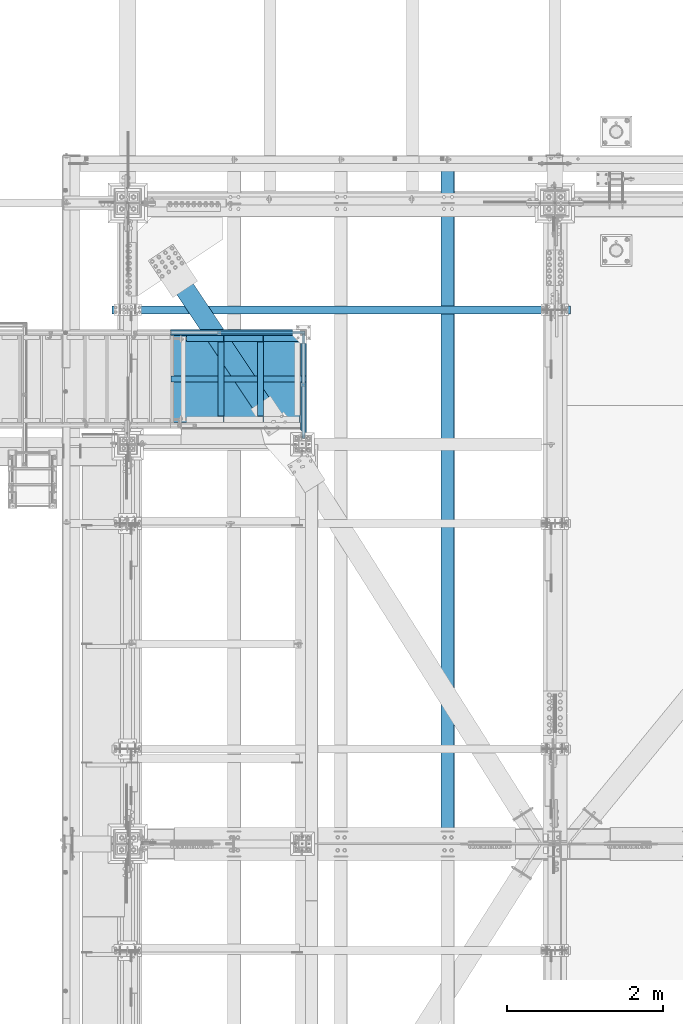
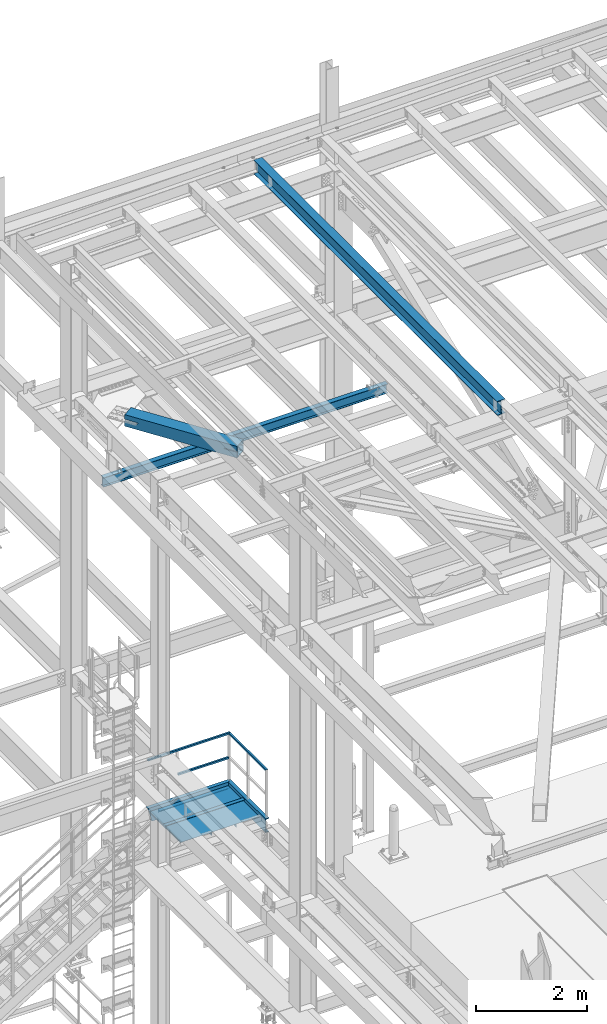
# One storey, part 1887 of 3843: 12 beams, 1 member, 7 elements without a shape of their own.
"""IFC2X3 building model written with IfcOpenShell, lengths in millimetres."""

from ifc_helpers import new_model, si_unit, frame, origin_with_axes, place, context, subcontext, project, spatial, faceted_brep, material, type_object, element, aggregate, save


model = new_model("IFC2X3")

# Units and contexts
model_context = context("Model", 3, precision=1e-05, world=origin_with_axes())
body_context = subcontext(model_context, "Body", "Model", "MODEL_VIEW")
ifc_project = project(units=[si_unit("LENGTHUNIT", "METRE", prefix="MILLI"), si_unit("AREAUNIT", "SQUARE_METRE"), si_unit("VOLUMEUNIT", "CUBIC_METRE"), si_unit("MASSUNIT", "GRAM", prefix="KILO"), si_unit("TIMEUNIT", "SECOND"), si_unit("PLANEANGLEUNIT", "RADIAN"), si_unit("SOLIDANGLEUNIT", "STERADIAN"), si_unit("THERMODYNAMICTEMPERATUREUNIT", "DEGREE_CELSIUS"), si_unit("LUMINOUSINTENSITYUNIT", "LUMEN")], contexts=[model_context])

# Site, building, storey
site_placement = place(None, origin_with_axes())
site = spatial("IfcSite", under=ifc_project, at=site_placement, CompositionType="ELEMENT")
building_placement = place(site_placement, origin_with_axes())
building = spatial("IfcBuilding", under=site, at=building_placement, Name="Undefined", CompositionType="ELEMENT")
storey_placement = place(building_placement, origin_with_axes())
storey = spatial("IfcBuildingStorey", under=building, at=storey_placement, Name="Undefined", CompositionType="ELEMENT", Elevation=0.0)

# Assembly, beam
assembly_1_placement = place(storey_placement, origin_with_axes())
assembly_1 = element("IfcElementAssembly", 1, at=assembly_1_placement, inside=storey, Name="RAIL", AssemblyPlace="NOTDEFINED", PredefinedType="RIGID_FRAME")
ifc_material_1 = material()
beam_type_1 = type_object("IfcBeamType", Name="HSS1-1/2X1-1/2X1/4", PredefinedType="NOTDEFINED")
beam_1_placement = place(assembly_1_placement, frame((38833.4250001418, 89211.15, 35204.399999695), z_axis=(0.0, 0.0, -1.0), x_axis=(0.0, 1.0, 0.0)))
beam_1 = element("IfcBeam", 2, at=beam_1_placement, type_object=beam_type_1, material=ifc_material_1, Name="RAIL", ObjectType="HSS1-1/2X1-1/2X1/4", context=body_context, shape_type="Brep", body=[
    faceted_brep([(-19.0499992359546, -19.0499992350015, -19.0499992350015), (-19.0499992359546, 19.0499992350015, -19.0499992350015), (1320.80000004543, 19.0499992350015, -19.0499992350015), (1320.80000004543, -19.0499992350015, -19.0499992350015), (19.0499992350015, -19.0499992350015, 19.0499992350015), (1320.80000004543, -19.0499999110762, 19.0499992350015), (19.0499992350015, 19.0499992350015, 19.0499992350015), (1320.80000004543, 19.0499992350015, 19.0499992350015), (12.6999993290483, 12.6999993299978, 12.6999993299978), (12.6999993290483, -12.6999993299978, 12.6999993299978), (-12.6999993309546, -12.6999993299978, -12.6999993299978), (-12.6999993309546, 12.6999993299978, -12.6999993299978), (1320.79999855565, 12.6999993299978, -12.6999993300014), (1320.80000004543, 12.6999993299978, 12.6999993299978), (1320.80000004543, -12.6999993299978, 12.6999993299978), (1320.79999855565, -12.6999993299978, -12.6999993300014)], [[[0, 1, 2, 3]], [[4, 0, 3, 5]], [[6, 4, 5, 7]], [[1, 6, 7, 2]], [[0, 4, 6, 1], [8, 9, 10, 11]], [[8, 11, 12, 13]], [[9, 8, 13, 14]], [[10, 9, 14, 15]], [[11, 10, 15, 12]], [[5, 3, 2, 7], [14, 13, 12, 15]]]),
])
aggregate(assembly_1, [beam_1])

# Assembly, beams
assembly_2_placement = place(storey_placement, origin_with_axes())
assembly_2 = element("IfcElementAssembly", 3, at=assembly_2_placement, inside=storey, Name="RAIL", AssemblyPlace="NOTDEFINED", PredefinedType="RIGID_FRAME")
beam_2_placement = place(assembly_2_placement, frame((37752.5642859121, 90551.0000000455, 34670.9999996949), z_axis=(0.0, 0.0, 1.0), x_axis=(1.0, 0.0, 0.0)))
beam_2 = element("IfcBeam", 4, at=beam_2_placement, type_object=beam_type_1, material=ifc_material_1, Name="RAIL", ObjectType="HSS1-1/2X1-1/2X1/4", context=body_context, shape_type="Brep", body=[
    faceted_brep([(1061.81071431866, -19.0500000000029, 19.0499992350015), (1061.81071435828, -19.0499992349942, -19.0499992350015), (1061.81071431866, 19.0499992349942, -19.0499992350015), (1061.81071431866, 19.0499992349942, 19.0499992350015), (1061.81071431866, -12.6999993299978, 12.6999993299978), (1061.81071431866, 12.6999993299978, 12.6999993299978), (1061.81071431866, 12.6999993299978, -12.6999993299978), (1061.81071431866, -12.6999993299978, -12.6999993299978), (19.0499992350015, 19.0499992350015, -19.0499992350015), (19.0499992350015, 19.0499992350015, 19.0499992350015), (19.0499992350015, -19.0499992350015, 19.0499992350015), (19.0499992350015, -19.0499992350015, -19.0499992350015), (19.0499992350015, 12.6999993299978, 12.6999993299978), (19.0499992350015, -12.6999993299978, 12.6999993299978), (19.0499992350015, -12.6999993299978, -12.6999993299978), (19.0499992350015, 12.6999993299978, -12.6999993299978)], [[[0, 1, 2, 3], [4, 5, 6, 7]], [[8, 9, 3, 2]], [[9, 10, 0, 3]], [[10, 11, 1, 0]], [[11, 8, 2, 1]], [[11, 10, 9, 8], [12, 13, 14, 15]], [[14, 13, 4, 7]], [[15, 14, 7, 6]], [[12, 15, 6, 5]], [[13, 12, 5, 4]]]),
])
beam_3_placement = place(assembly_2_placement, frame((38852.4750002307, 90551.0000000455, 35204.3999996949), z_axis=(0.0, 0.0, -1.0), x_axis=(-1.0, 0.0, 0.0)))
beam_3 = element("IfcBeam", 5, at=beam_3_placement, type_object=beam_type_1, material=ifc_material_1, Name="RAIL", ObjectType="HSS1-1/2X1-1/2X1/4", context=body_context, shape_type="Brep", body=[
    faceted_brep([(6.34999999999854, 12.6999993299978, -12.6999993299978), (6.34999999999854, -12.6999993299978, -12.6999993299978), (1721.30928479847, -12.6999993299978, -12.6999993299978), (1721.30928479847, 12.6999993299978, -12.6999993299978), (31.7500007135677, -12.6999993300014, 12.6999993299978), (1714.04071512254, -12.6999993299978, 12.6999993299978), (31.7500007135677, 12.6999993300014, 12.6999993299978), (1714.04071512254, 12.6999993299978, 12.6999993299978), (0.0, 19.0500000000029, -19.0499999999993), (38.0999984699883, 19.0499992350015, 19.0499992350015), (1712.22357263487, 19.0499992349942, 19.0499992350015), (1723.12642728614, 19.0499992349942, -19.0499992350015), (38.0999984699883, -19.0499992350015, 19.0499992350015), (1712.22357263487, -19.0499992349942, 19.0499992350015), (0.0, -19.0499992350015, -19.0499992350015), (1723.12642728614, -19.0499992349942, -19.0499992350015)], [[[0, 1, 2, 3]], [[1, 4, 5, 2]], [[4, 6, 7, 5]], [[6, 0, 3, 7]], [[8, 9, 10, 11]], [[9, 12, 13, 10]], [[12, 14, 15, 13]], [[14, 8, 11, 15]], [[13, 15, 11, 10], [5, 7, 3, 2]], [[14, 12, 9, 8], [6, 4, 1, 0]]]),
])
aggregate(assembly_2, [beam_2, beam_3])

assembly_3_placement = place(storey_placement, origin_with_axes())
assembly_3 = element("IfcElementAssembly", 6, at=assembly_3_placement, inside=storey, Name="STAIR", AssemblyPlace="NOTDEFINED", PredefinedType="RIGID_FRAME")
ifc_material_2 = material(Name="STEEL/A36")
beam_type_2 = type_object("IfcBeamType", Name="C12X20.7", PredefinedType="NOTDEFINED")
beam_4_placement = place(assembly_3_placement, frame((38833.4249999936, 89115.9000000001, 34010.6), z_axis=(0.0, 0.0, 1.0), x_axis=(0.0, 1.0, 0.0)))
beam_4 = element("IfcBeam", 7, at=beam_4_placement, type_object=beam_type_2, material=ifc_material_2, Name="STAIR", ObjectType="C12X20.7", context=body_context, shape_type="Brep", body=[
    faceted_brep([(1401.4901281567, 33.6098719394649, 146.050000096482), (1390.65000009617, 38.0999999999985, 150.540128157008), (1388.01974411152, 38.0999999999985, 152.400000000001), (1464.21974411151, -38.0999999999985, 152.400000000001), (1473.20000009616, -38.0999999999985, 146.047460000002), (1388.0197441115, 38.0999999999985, -152.400000000001), (1390.65000009617, 38.0999999999985, -150.540128156994), (1401.4901281567, 33.6098719394649, -146.050000096475), (1473.20000009616, -38.0999999999985, -146.047460000002), (1464.2197441115, -38.0999999999985, -152.400000000001), (63.4999999998981, -38.0999999999985, -146.047460000002), (63.4999999998981, -38.0999999999985, -152.400000000001), (63.4999999998981, 30.1624999999985, -134.674927499997), (1404.93750009616, 30.1624999999985, -134.674927499997), (63.4999999998981, 30.1624999999985, 134.674927499997), (1404.93750009616, 30.1624999999985, 134.674927499997), (63.4999999998981, -38.0999999999985, 146.047460000002), (63.4999999998981, -38.0999999999985, 152.400000000001), (63.4999999998981, 38.0999999999985, 152.400000000001), (63.4999999998981, 38.0999999999985, -152.400000000001)], [[[0, 1, 2, 3, 4]], [[5, 6, 7, 8, 9]], [[7, 6, 1, 0]], [[10, 11, 9, 8]], [[12, 10, 8, 13]], [[14, 12, 13, 15]], [[16, 14, 15, 4]], [[17, 16, 4, 3]], [[18, 17, 3, 2]], [[11, 10, 12, 14, 16, 17, 18, 19]], [[11, 19, 5, 9]], [[15, 13, 8, 7, 0, 4]], [[6, 5, 19, 18, 2, 1]]]),
])
beam_5_placement = place(assembly_3_placement, frame((38871.525, 90551.0000000963, 34010.5999999998), z_axis=(0.0, 0.0, 1.0), x_axis=(-1.0, 0.0, 0.0)))
beam_5 = element("IfcBeam", 8, at=beam_5_placement, type_object=beam_type_2, material=ifc_material_2, Name="STAIR", ObjectType="C12X20.7", context=body_context, shape_type="Brep", body=[
    faceted_brep([(76.2000000064072, 38.1000000000058, -152.400000000001), (76.2000000064072, 38.1000000000058, 152.400000000001), (1743.99357001703, 38.1000000000058, 152.400000000001), (1656.77072930426, 38.1000000000058, -152.400000000001), (0.0, -38.0999999999985, 152.400000000001), (1743.99357001703, -38.1000000000058, 152.400000000001), (0.0, -38.0999999999985, 146.047460000002), (1742.17570064518, -38.1000000000058, 146.047460000002), (68.2625000000044, 30.1624999999985, 134.674927499997), (1738.92128925821, 30.1625000000058, 134.674927499997), (68.2625000000044, 30.1624999999985, -134.674927499997), (1661.84301006309, 30.1625000000058, -134.674927499997), (0.0, -38.0999999999985, -146.047460000002), (1658.58859867612, -38.1000000000058, -146.047460000002), (0.0, -38.0999999999985, -152.400000000001), (1656.77072930426, -38.1000000000058, -152.400000000001)], [[[0, 1, 2, 3]], [[1, 4, 5, 2]], [[4, 6, 7, 5]], [[6, 8, 9, 7]], [[8, 10, 11, 9]], [[10, 12, 13, 11]], [[12, 14, 15, 13]], [[14, 0, 3, 15]], [[5, 7, 9, 11, 13, 15, 3, 2]], [[14, 12, 10, 8, 6, 4, 1, 0]]]),
])

# Assembly, beam
assembly_4_placement = place(storey_placement, origin_with_axes())
assembly_4 = element("IfcElementAssembly", 9, at=assembly_4_placement, inside=storey, Name="BEAM", AssemblyPlace="NOTDEFINED", PredefinedType="RIGID_FRAME")
ifc_material_3 = material(Name="STEEL/A992")
beam_type_3 = type_object("IfcBeamType", Name="W12X26", PredefinedType="NOTDEFINED")
beam_6_placement = place(assembly_4_placement, frame((40687.509262353, 83985.1349347832, 45662.9566294508), z_axis=(-0.0211520975410895, 0.000224553000021843, 0.999776244139439), x_axis=(0.0, 0.999999974776746, -0.000224602999950078)))
beam_6 = element("IfcBeam", 10, at=beam_6_placement, type_object=beam_type_3, material=ifc_material_3, Name="BEAM", ObjectType="W12X26", context=body_context, shape_type="Brep", body=[
    faceted_brep([(8748.71311540117, -3.17500000010477, -146.049999983072), (8748.71311540117, -82.5499999999593, -146.049999983014), (8748.71311540123, -82.549999999952, -155.574999982986), (8748.71311540125, 82.5499999997628, -155.574999983102), (8748.71311540117, 82.5499999997483, -146.04999998313), (8748.71311540117, 3.1749999998865, -146.049999983079), (8748.71311540167, 3.1749999998865, -142.874999540705), (8748.71311540162, -3.17500000011205, -142.874999540683), (8749.67984532419, 3.17499999987194, -138.014920022666), (8749.67984532416, -3.17500000011205, -138.014920022644), (8752.43285922469, 3.17499999986467, -133.894743554527), (8752.43285922465, -3.1750000001266, -133.894743554505), (8756.55303569289, 3.17499999985739, -131.141729654068), (8756.55303569286, -3.17500000013388, -131.141729654046), (8761.41311521103, 3.17499999985739, -130.174999731513), (8761.41311521101, -3.17500000013388, -130.174999731491), (8818.55700377848, -3.17500000013388, -130.174999732226), (8818.55703394623, 3.17499999985739, -130.174999732219), (12.6322846896801, 3.17499999975553, 146.049999999632), (12.6326617865998, 82.5499999996173, 146.049999999574), (8748.71311539768, 82.549999999268, 146.050000016097), (8748.71311539767, 3.17499999941356, 146.050000016156), (12.699601046821, -82.5500000001557, -155.574999999742), (12.6974692860676, -82.54999999961, -146.049999999537), (12.6977969192812, -3.17500000026484, -146.049999999916), (12.63225452193, -3.17500000023574, 146.049999999646), (12.6318774249958, -82.5500000000975, 146.049999999697), (12.629738559961, -82.550000000112, 155.574999999677), (12.630522921565, 82.5499999995955, 155.574999999553), (12.6978276350128, 3.17499999971187, -146.04999999993), (12.6982115817373, 82.5499999995736, -146.050000000097), (12.7003686724711, 82.5499999999884, -155.574999999677), (8748.71311539768, -3.17500000058499, 146.050000016156), (8748.71311539767, -82.5500000004467, 146.050000016221), (8748.71311539761, -82.5500000004613, 155.575000016193), (8748.71311539761, 82.5499999992462, 155.575000016077), (8748.71311539839, -3.17500000057771, 142.875000076056), (8748.71311539842, 3.17499999940628, 142.875000076041), (8749.67984532106, -3.17500000057771, 138.014920558082), (8749.67984532111, 3.17499999942083, 138.014920558067), (8752.4328592216, -3.17500000056316, 133.894744089979), (8752.43285922163, 3.17499999942083, 133.894744089965), (8756.55303568982, -3.17500000056316, 131.141730189527), (8756.55303568985, 3.17499999942083, 131.141730189505), (8761.41311520792, -3.17500000056316, 130.175000266914), (8761.41311520795, 3.17499999942811, 130.1750002669), (8818.49854146753, -3.17500000057044, 130.175000267431), (8818.4985716353, 3.17499999942811, 130.175000267445), (8818.5532037197, 3.17499999982101, -113.117865648703), (8818.50142185467, 3.17499999944266, 117.482128538446)], [[[0, 1, 2, 3, 4, 5, 6, 7]], [[7, 6, 8, 9]], [[9, 8, 10, 11]], [[11, 10, 12, 13]], [[13, 12, 14, 15]], [[16, 15, 14, 17]], [[18, 19, 20, 21]], [[22, 23, 24, 25, 26, 27, 28, 19, 18, 29, 30, 31]], [[26, 25, 32, 33]], [[27, 26, 33, 34]], [[28, 27, 34, 35]], [[19, 28, 35, 20]], [[34, 33, 32, 36, 37, 21, 20, 35]], [[38, 39, 37, 36]], [[40, 41, 39, 38]], [[42, 43, 41, 40]], [[44, 45, 43, 42]], [[46, 47, 45, 44]], [[48, 49, 47, 46, 16, 17]], [[12, 10, 8, 6, 5, 29, 18, 21, 37, 39, 41, 43, 45, 47, 49, 48, 17, 14]], [[30, 29, 5, 4]], [[31, 30, 4, 3]], [[22, 31, 3, 2]], [[23, 22, 2, 1]], [[24, 23, 1, 0]], [[46, 44, 42, 40, 38, 36, 32, 25, 24, 0, 7, 9, 11, 13, 15, 16]]]),
])
aggregate(assembly_4, [beam_6])

# Beam
beam_type_4 = type_object("IfcBeamType", Name="L3X3X1/4", PredefinedType="NOTDEFINED")
beam_7_placement = place(assembly_3_placement, frame((37772.974999991, 90506.5500001432, 34048.7000000116), z_axis=(-1.0, 0.0, 0.0), x_axis=(0.0, -1.0, 0.0)))
beam_7 = element("IfcBeam", 11, at=beam_7_placement, type_object=beam_type_4, material=ifc_material_2, Name="ANGLE", ObjectType="L3X3X1/4", context=body_context, shape_type="Brep", body=[
    faceted_brep([(1035.05000022112, 31.75, 38.0999999999985), (1035.05000022112, 31.75, -31.75), (1035.05000022112, 31.7499999999927, -38.0999999999985), (1028.70000022053, 38.0999999999985, -38.0999999999985), (1028.70000022053, 38.0999999999985, 38.0999999999985), (1092.20000022113, 31.75, -31.75), (1092.20000022113, 31.7499999999927, -38.0999999999985), (1104.90000022113, 19.0499999999884, -31.75), (1104.90000015372, 19.0499999999884, -38.0999999999985), (76.2000000006228, 38.0999999999985, 38.0999999999985), (76.2000000006228, 38.0999999999985, -38.0999999999985), (69.8500000000349, 31.7499999999927, -38.0999999999985), (69.8500000000349, 31.75, -31.75), (69.8500000000349, 31.75, 38.0999999999985), (12.7000000000262, 31.7499999999927, -38.0999999999985), (12.7000000000262, 31.75, -31.75), (0.0, 19.0499999999884, -38.0999999999985), (0.0, 19.0500000000029, -31.75), (0.0, -38.0999999999985, -38.0999999999985), (0.0, -38.0999999999985, -31.75), (1104.90000015372, -38.0999999999985, -38.0999999999985), (1104.90000015372, -38.0999999999985, -31.75)], [[[0, 1, 2, 3, 4]], [[5, 6, 2, 1]], [[7, 8, 6, 5]], [[9, 10, 11, 12, 13]], [[12, 11, 14, 15]], [[15, 14, 16, 17]], [[18, 19, 17, 16]], [[19, 18, 20, 21]], [[1, 12, 15, 17, 19, 21, 7, 5]], [[13, 12, 1, 0]], [[9, 13, 0, 4]], [[10, 9, 4, 3]], [[20, 18, 16, 14, 11, 10, 3, 2, 6, 8]], [[21, 20, 8, 7]]]),
])

beam_8_placement = place(assembly_3_placement, frame((38284.1499999923, 90506.5500001432, 34048.7000000114), z_axis=(-1.0, 0.0, 0.0), x_axis=(0.0, -1.0, 0.0)))
beam_8 = element("IfcBeam", 12, at=beam_8_placement, type_object=beam_type_4, material=ifc_material_2, Name="ANGLE", ObjectType="L3X3X1/4", context=body_context, shape_type="Brep", body=[
    faceted_brep([(1035.05000022112, 31.75, 38.0999999999985), (1035.05000022112, 31.75, -31.75), (1035.05000022112, 31.7499999999927, -38.0999999999985), (1028.70000022053, 38.0999999999985, -38.0999999999985), (1028.70000022053, 38.0999999999985, 38.0999999999985), (1092.20000022113, 31.75, -31.75), (1092.20000022113, 31.7499999999927, -38.0999999999985), (1104.90000022113, 19.0499999999884, -31.75), (1104.90000015372, 19.0499999999884, -38.0999999999985), (76.2000000006228, 38.0999999999985, 38.0999999999985), (76.2000000006228, 38.0999999999985, -38.0999999999985), (69.8500000000349, 31.7499999999927, -38.0999999999985), (69.8500000000349, 31.75, -31.75), (69.8500000000349, 31.75, 38.0999999999985), (12.7000000000262, 31.7499999999927, -38.0999999999985), (12.7000000000262, 31.75, -31.75), (0.0, 19.0499999999884, -38.0999999999985), (0.0, 19.0500000000029, -31.75), (0.0, -38.0999999999985, -38.0999999999985), (0.0, -38.0999999999985, -31.75), (1104.90000015372, -38.0999999999985, -38.0999999999985), (1104.90000015372, -38.0999999999985, -31.75)], [[[0, 1, 2, 3, 4]], [[5, 6, 2, 1]], [[7, 8, 6, 5]], [[9, 10, 11, 12, 13]], [[12, 11, 14, 15]], [[15, 14, 16, 17]], [[18, 19, 17, 16]], [[19, 18, 20, 21]], [[1, 12, 15, 17, 19, 21, 7, 5]], [[13, 12, 1, 0]], [[9, 13, 0, 4]], [[10, 9, 4, 3]], [[20, 18, 16, 14, 11, 10, 3, 2, 6, 8]], [[21, 20, 8, 7]]]),
])

beam_9_placement = place(assembly_3_placement, frame((37331.6499999897, 90474.8000000479, 34048.7000000116), z_axis=(0.0, -1.0, 0.0), x_axis=(1.0, 0.0, 0.0)))
beam_9 = element("IfcBeam", 13, at=beam_9_placement, type_object=beam_type_4, material=ifc_material_2, Name="ANGLE", ObjectType="L3X3X1/4", context=body_context, shape_type="Brep", body=[
    faceted_brep([(0.0, 38.0999999999985, -38.0999999999985), (0.0, 38.0999999999985, 38.0999999999985), (1450.97500000388, 38.0999999999985, 38.1000000000058), (1450.97500000388, 38.0999999999985, -38.1000000000058), (0.0, 31.75, 38.0999999999985), (1450.97500000388, 31.75, 38.1000000000058), (0.0, 31.75, -31.75), (1450.97500000388, 31.75, -31.75), (0.0, -38.0999999999985, -31.75), (1450.97500000388, -38.0999999999985, -31.75), (0.0, -38.0999999999985, -38.0999999999985), (1450.97500000388, -38.0999999999985, -38.1000000000058)], [[[0, 1, 2, 3]], [[1, 4, 5, 2]], [[4, 6, 7, 5]], [[6, 8, 9, 7]], [[8, 10, 11, 9]], [[10, 0, 3, 11]], [[5, 7, 9, 11, 3, 2]], [[10, 8, 6, 4, 1, 0]]]),
])

# Assembly, member
assembly_5_placement = place(storey_placement, origin_with_axes())
assembly_5 = element("IfcElementAssembly", 14, at=assembly_5_placement, inside=storey, Name="ref.", AssemblyPlace="NOTDEFINED", PredefinedType="RIGID_FRAME")
ifc_material_4 = material(Name="STEEL/Steel_Undefined")
member_type = type_object("IfcMemberType", PredefinedType="NOTDEFINED")
member_placement = place(assembly_5_placement, frame((37134.8000002307, 89954.1000000455, 34134.424999695), z_axis=(0.0, 1.0, 0.0), x_axis=(1.0, 0.0, 0.0)))
member = element("IfcMember", 15, at=member_placement, type_object=member_type, material=ifc_material_4, Name="ref.", context=body_context, shape_type="Brep", body=[
    faceted_brep([(0.0, 3.17500000000291, -38.0999999999985), (0.0, 3.17500000000291, 38.0999999999985), (1736.7249997629, 3.17500000000291, 38.1000000000058), (1736.7249997629, 3.17500000000291, -38.1000000000058), (0.0, -3.17500000000291, 38.0999999999985), (1736.7249997629, -3.17500000000291, 38.1000000000058), (0.0, -3.17500000000291, -38.0999999999985), (1736.7249997629, -3.17500000000291, -38.1000000000058)], [[[0, 1, 2, 3]], [[1, 4, 5, 2]], [[4, 6, 7, 5]], [[6, 0, 3, 7]], [[5, 7, 3, 2]], [[6, 4, 1, 0]]]),
])
aggregate(assembly_5, [member])

# Beam
ifc_material_5 = material(Name="STEEL/ASTM A1011")
beam_type_5 = type_object("IfcBeamType", PredefinedType="NOTDEFINED")
beam_10_placement = place(assembly_3_placement, frame((38788.9749999936, 89954.1000000803, 34088.3875000126), z_axis=(0.0, -1.0, 0.0), x_axis=(-1.0, 0.0, 0.0)))
beam_10 = element("IfcBeam", 16, at=beam_10_placement, type_object=beam_type_5, material=ifc_material_5, Name="PAN", context=body_context, shape_type="Brep", body=[
    faceted_brep([(0.0, -1.58750000000146, -558.799999999999), (0.0, -1.58750000000146, 558.799999999999), (0.0, 1.58750000000146, 558.799999999999), (0.0, 1.58750000000146, -558.799999999999), (1643.05890307978, 1.58750000000146, 558.800000000003), (1643.05890307978, 1.58750000000146, -558.800000000003), (1640.34949805721, -1.58750000000146, -558.800000000003), (1640.34949805721, -1.58750000000146, 558.800000000003), (1648.98308362037, -35.6143980153938, 558.800000000003), (1648.98308362037, -35.6143980153938, -558.800000000003), (1645.84759068324, -36.1137065785078, 558.800000000003), (1645.84759068324, -36.1137065785078, -558.800000000003)], [[[0, 1, 2, 3]], [[3, 2, 4, 5]], [[1, 0, 6, 7]], [[5, 4, 8, 9]], [[4, 2, 1, 7, 10, 8]], [[7, 6, 11, 10]], [[6, 0, 3, 5, 9, 11]], [[10, 11, 9, 8]]]),
])

aggregate(assembly_3, [beam_7, beam_8, beam_9, beam_10, beam_4, beam_5])

# Assembly, beam
assembly_6_placement = place(storey_placement, origin_with_axes())
assembly_6 = element("IfcElementAssembly", 17, at=assembly_6_placement, inside=storey, Name="BEAM", AssemblyPlace="NOTDEFINED", PredefinedType="RIGID_FRAME")
beam_type_6 = type_object("IfcBeamType", Name="W8X13", PredefinedType="NOTDEFINED")
beam_11_placement = place(assembly_6_placement, frame((36372.8, 90843.1, 41402.0), z_axis=(0.0, 0.0, 1.0), x_axis=(1.0, 0.0, 0.0)))
beam_11 = element("IfcBeam", 18, at=beam_11_placement, type_object=beam_type_6, material=ifc_material_3, Name="BEAM", ObjectType="W8X13", context=body_context, shape_type="Brep", body=[
    faceted_brep([(0.0, 50.7999999999993, -101.599999999999), (0.0, 50.7999999999993, -95.25), (5892.8, 50.7999999999993, -95.25), (5892.8, 50.7999999999993, -101.599999999999), (0.0, 3.17499999999927, -95.25), (5892.8, 3.17499999999927, -95.25), (-2.44140610448085e-05, 3.17500000000291, 95.2499999999927), (5892.8, 3.17499999999927, 95.25), (0.0, 50.7999999999993, 95.25), (5892.8, 50.7999999999993, 95.25), (0.0, 50.7999999999993, 101.599999999999), (5892.8, 50.7999999999993, 101.599999999999), (0.0, -50.7999999999993, 101.599999999999), (5892.8, -50.7999999999993, 101.599999999999), (0.0, -50.7999999999993, 95.25), (5892.8, -50.7999999999993, 95.25), (0.0, -3.17499999999927, 95.25), (5892.8, -3.17499999999927, 95.25), (0.0, -3.17499999999927, -95.25), (5892.8, -3.17499999999927, -95.25), (0.0, -50.7999999999993, -95.25), (5892.8, -50.7999999999993, -95.25), (0.0, -50.7999999999993, -101.599999999999), (5892.8, -50.7999999999993, -101.599999999999)], [[[0, 1, 2, 3]], [[1, 4, 5, 2]], [[4, 6, 7, 5]], [[6, 8, 9, 7]], [[8, 10, 11, 9]], [[10, 12, 13, 11]], [[12, 14, 15, 13]], [[14, 16, 17, 15]], [[16, 18, 19, 17]], [[18, 20, 21, 19]], [[20, 22, 23, 21]], [[22, 0, 3, 23]], [[5, 7, 9, 11, 13, 15, 17, 19, 21, 23, 3, 2]], [[22, 20, 18, 16, 14, 12, 10, 8, 6, 4, 1, 0]]]),
])
aggregate(assembly_6, [beam_11])

assembly_7_placement = place(storey_placement, origin_with_axes())
assembly_7 = element("IfcElementAssembly", 19, at=assembly_7_placement, inside=storey, AssemblyPlace="NOTDEFINED", PredefinedType="RIGID_FRAME")
ifc_material_6 = material()
beam_type_7 = type_object("IfcBeamType", Name="HSS10X10X3/4", PredefinedType="NOTDEFINED")
beam_12_placement = place(assembly_7_placement, frame((36576.0, 92214.7, 42246.55), z_axis=(0.832050294337848, 0.554700196225222, 0.0), x_axis=(0.55470019622522, -0.83205029433785, 0.0)))
beam_12 = element("IfcBeam", 20, at=beam_12_placement, type_object=beam_type_7, material=ifc_material_6, ObjectType="HSS10X10X3/4", context=body_context, shape_type="Brep", body=[
    faceted_brep([(1079.97091254695, 1.58750000000146, 127.00000000016), (1079.97091254695, 1.58750000000146, 107.950000000143), (1332.38341217002, 1.58750000000146, 107.950000000143), (1332.38341217002, 1.58750000000146, 127.00000000016), (1337.85100185593, 0.499928791716229, 107.950000000128), (1337.85100185593, 0.499928791716229, 127.00000000016), (1342.48620057599, -2.59721197552426, 107.950000000143), (1342.48620057599, -2.59721197552426, 127.00000000016), (1345.58334134326, -7.23241069557116, 107.950000000143), (1345.58334134325, -7.23241069557116, 127.00000000016), (1332.38341217002, -26.9874999999956, 127.00000000016), (1332.38341217002, -26.9874999999956, 107.950000000143), (1079.97091254695, -26.9874999999956, 107.950000000143), (1079.97091254695, -26.9874999999956, 127.00000000016), (1337.85100185593, -25.8999287917104, 127.00000000016), (1337.85100185593, -25.8999287917104, 107.950000000128), (1342.48620057599, -22.8027880244699, 127.00000000016), (1342.48620057599, -22.8027880244699, 107.950000000143), (1345.58334134325, -18.167589304423, 127.00000000016), (1345.58334134326, -18.167589304423, 107.950000000143), (1346.67091255153, -12.6999996185259, 127.00000000016), (1346.67091255154, -12.6999996185259, 107.950000000143), (1079.97091254695, 1.58750000000146, -107.950000000114), (1079.97091254695, 1.58750000000146, -127.000000000146), (1332.38341217002, 1.58750000000146, -127.000000000146), (1332.38341217002, 1.58750000000146, -107.950000000128), (1337.85100185593, 0.499928791716229, -127.000000000146), (1337.85100185593, 0.499928791716229, -107.950000000128), (1342.48620057599, -2.59721197552426, -127.000000000146), (1342.48620057599, -2.59721197552426, -107.950000000128), (1345.58334134326, -7.23241069557116, -127.000000000146), (1345.58334134326, -7.23241069557116, -107.950000000114), (1332.38341217002, -26.9874999999956, -107.950000000128), (1332.38341217002, -26.9874999999956, -127.000000000146), (1079.97091254695, -26.9874999999956, -127.000000000146), (1079.97091254695, -26.9874999999956, -107.950000000114), (1337.85100185593, -25.8999287917104, -107.950000000128), (1337.85100185593, -25.8999287917104, -127.000000000146), (1342.48620057599, -22.8027880244699, -107.950000000128), (1342.48620057599, -22.8027880244699, -127.000000000146), (1345.58334134326, -18.167589304423, -107.950000000114), (1345.58334134326, -18.167589304423, -127.000000000146), (1346.67091255155, -12.6999996185259, -107.950000000128), (1346.67091255153, -12.6999996185259, -127.000000000131), (1079.97091254695, 107.949999999997, 107.950000000143), (1079.97091254695, 107.949999999997, -107.950000000114), (3331.67021918097, 107.949999999997, -107.950000000128), (3331.67021918095, 107.949999999997, 107.950000000143), (1079.97091254695, 127.0, -127.000000000146), (3331.67021918096, 127.0, -127.000000000146), (3331.67021918096, 1.58750000000146, -127.000000000146), (3079.25771917657, 1.58750000000146, -127.000000000146), (3076.22016943217, 0.983293789307936, -127.000000000146), (3073.64505910089, -0.737339924329717, -127.000000000146), (3071.92442538725, -3.31245025560202, -127.000000000146), (3071.32021917655, -6.34999999999854, -127.000000000146), (3071.92442538725, -9.38754974439507, -127.000000000146), (3073.64505910089, -11.9626600756674, -127.000000000146), (3076.22016943217, -13.683293789305, -127.000000000146), (3079.25771917657, -14.2874999999985, -127.000000000146), (3331.67021918096, -14.2874999999985, -127.000000000146), (3331.67021918096, -127.0, -127.000000000146), (1079.97091254695, -127.0, -127.000000000146), (3331.67021918097, 1.58750000000146, -107.950000000128), (3079.25771917659, 1.58750000000146, -107.950000000114), (3076.22016943217, 0.983293789307936, -107.950000000128), (3073.64505910089, -0.737339924329717, -107.950000000114), (3071.92442538726, -3.31245025560202, -107.950000000114), (3071.32021917655, -6.34999999999854, -107.950000000114), (3071.92442538726, -9.38754974439507, -107.950000000114), (3073.64505910089, -11.9626600756674, -107.950000000114), (3076.22016943217, -13.683293789305, -107.950000000128), (3079.25771917659, -14.2874999999985, -107.950000000114), (3331.67021918097, -14.2874999999985, -107.950000000128), (1079.97091254695, -107.949999999997, -107.950000000114), (1079.97091254695, -107.949999999997, 107.950000000143), (3331.67021918095, -107.949999999997, 107.950000000143), (3331.67021918097, -107.949999999997, -107.950000000128), (3076.22016943217, 0.983293789307936, 127.00000000016), (3076.22016943217, 0.983293789307936, 107.950000000128), (3079.25771917659, 1.58750000000146, 107.950000000143), (3079.25771917659, 1.58750000000146, 127.00000000016), (3073.64505910089, -0.737339924329717, 127.00000000016), (3073.64505910089, -0.737339924329717, 107.950000000143), (3071.92442538724, -3.31245025560202, 127.00000000016), (3071.92442538726, -3.31245025560202, 107.950000000143), (3071.32021917654, -6.34999999999854, 127.00000000016), (3071.32021917657, -6.34999999999854, 107.950000000143), (3071.92442538724, -9.38754974439507, 127.00000000016), (3071.92442538726, -9.38754974439507, 107.950000000143), (3073.64505910089, -11.9626600756674, 127.00000000016), (3073.64505910089, -11.9626600756674, 107.950000000143), (3076.22016943217, -13.683293789305, 127.00000000016), (3076.22016943217, -13.683293789305, 107.950000000128), (3079.25771917659, -14.2874999999985, 127.00000000016), (3079.25771917659, -14.2874999999985, 107.950000000143), (3331.67021918095, -14.2874999999985, 127.00000000016), (3331.67021918095, -14.2874999999985, 107.950000000143), (3331.67021918095, -127.0, 127.00000000016), (1079.97091254695, -127.0, 127.00000000016), (3331.67021918095, 1.58750000000146, 107.950000000143), (3331.67021918095, 1.58750000000146, 127.00000000016), (3331.67021918095, 127.0, 127.00000000016), (1079.97091254695, 127.0, 127.00000000016)], [[[0, 1, 2, 3]], [[3, 2, 4, 5]], [[5, 4, 6, 7]], [[7, 6, 8, 9]], [[10, 11, 12, 13]], [[14, 15, 11, 10]], [[16, 17, 15, 14]], [[18, 19, 17, 16]], [[20, 21, 19, 18]], [[9, 8, 21, 20]], [[22, 23, 24, 25]], [[25, 24, 26, 27]], [[27, 26, 28, 29]], [[29, 28, 30, 31]], [[32, 33, 34, 35]], [[36, 37, 33, 32]], [[38, 39, 37, 36]], [[40, 41, 39, 38]], [[42, 43, 41, 40]], [[31, 30, 43, 42]], [[44, 45, 46, 47]], [[28, 26, 24, 23, 48, 49, 50, 51, 52, 53, 54, 55, 56, 57, 58, 59, 60, 61, 62, 34, 33, 37, 39, 41, 43, 30]], [[63, 64, 51, 50]], [[65, 52, 51, 64]], [[66, 53, 52, 65]], [[67, 54, 53, 66]], [[68, 55, 54, 67]], [[69, 56, 55, 68]], [[70, 57, 56, 69]], [[71, 58, 57, 70]], [[72, 59, 58, 71]], [[73, 60, 59, 72]], [[74, 75, 76, 77]], [[78, 79, 80, 81]], [[82, 83, 79, 78]], [[84, 85, 83, 82]], [[86, 87, 85, 84]], [[88, 89, 87, 86]], [[90, 91, 89, 88]], [[92, 93, 91, 90]], [[94, 95, 93, 92]], [[96, 97, 95, 94]], [[98, 61, 60, 73, 77, 76, 97, 96]], [[99, 62, 61, 98]], [[75, 74, 35, 34, 62, 99, 13, 12]], [[6, 4, 2, 1, 44, 47, 100, 80, 79, 83, 85, 87, 89, 91, 93, 95, 97, 76, 75, 12, 11, 15, 17, 19, 21, 8]], [[101, 81, 80, 100]], [[47, 46, 63, 50, 49, 102, 101, 100]], [[48, 103, 102, 49]], [[16, 14, 10, 13, 99, 98, 96, 94, 92, 90, 88, 86, 84, 82, 78, 81, 101, 102, 103, 0, 3, 5, 7, 9, 20, 18]], [[103, 48, 23, 22, 45, 44, 1, 0]], [[38, 36, 32, 35, 74, 77, 73, 72, 71, 70, 69, 68, 67, 66, 65, 64, 63, 46, 45, 22, 25, 27, 29, 31, 42, 40]]]),
])
aggregate(assembly_7, [beam_12])

save(model, "model.ifc")
